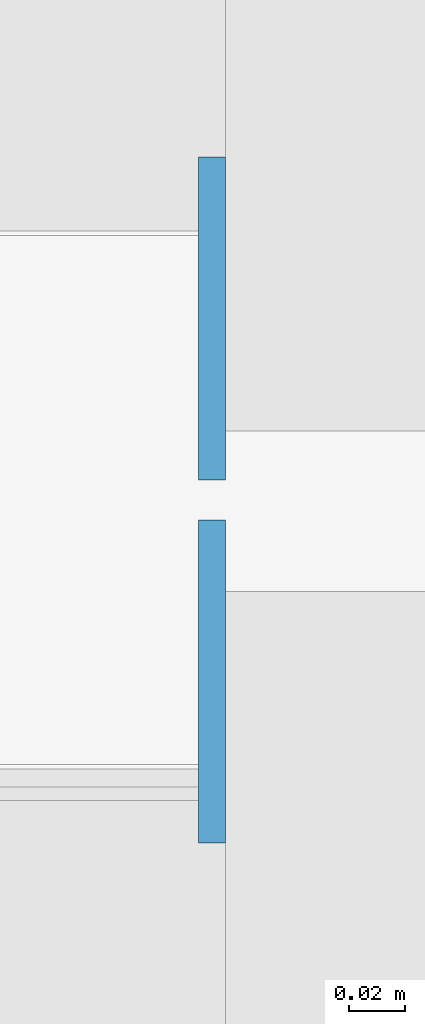
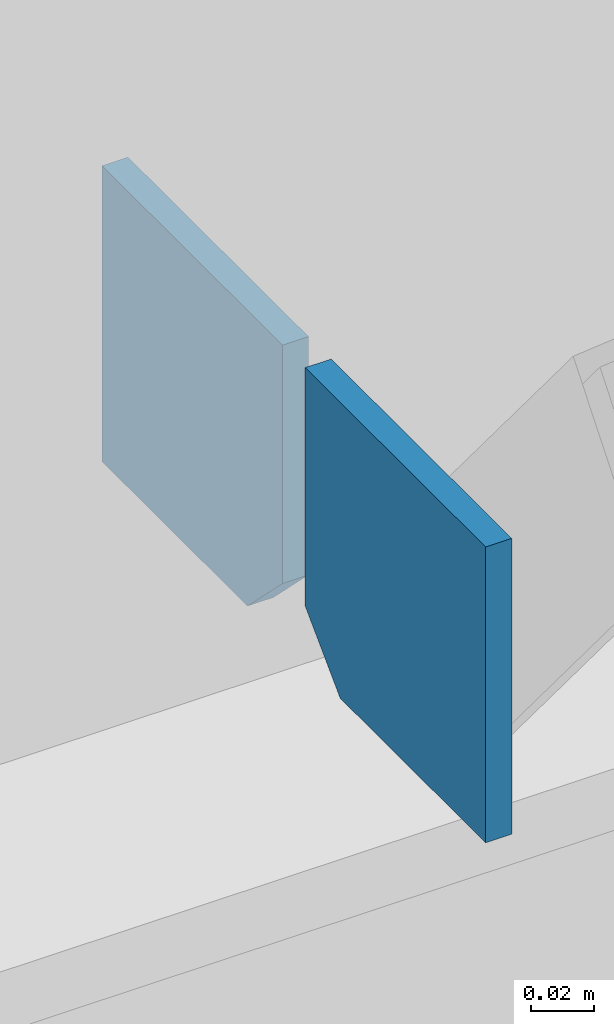
# One storey, part 513 of 1179: 2 columns, 1 element without a shape of its own.
"""IFC2X3 building model written with IfcOpenShell, lengths in millimetres."""

from ifc_helpers import new_model, si_unit, frame, origin_with_axes, place, context, subcontext, project, spatial, faceted_brep, material, type_object, element, aggregate, save


model = new_model("IFC2X3")

# Units and contexts
model_context = context("Model", 3, precision=1e-05, world=origin_with_axes())
body_context = subcontext(model_context, "Body", "Model", "MODEL_VIEW")
ifc_project = project(units=[si_unit("LENGTHUNIT", "METRE", prefix="MILLI"), si_unit("AREAUNIT", "SQUARE_METRE"), si_unit("VOLUMEUNIT", "CUBIC_METRE"), si_unit("MASSUNIT", "GRAM", prefix="KILO"), si_unit("TIMEUNIT", "SECOND"), si_unit("PLANEANGLEUNIT", "RADIAN"), si_unit("SOLIDANGLEUNIT", "STERADIAN"), si_unit("THERMODYNAMICTEMPERATUREUNIT", "DEGREE_CELSIUS"), si_unit("LUMINOUSINTENSITYUNIT", "LUMEN")], contexts=[model_context])

# Site, building, storey
site_placement = place(None, origin_with_axes())
site = spatial("IfcSite", under=ifc_project, at=site_placement, CompositionType="ELEMENT")
building_placement = place(site_placement, origin_with_axes())
building = spatial("IfcBuilding", under=site, at=building_placement, Name="Undefined", CompositionType="ELEMENT")
storey_placement = place(building_placement, origin_with_axes())
storey = spatial("IfcBuildingStorey", under=building, at=storey_placement, Name="Undefined", CompositionType="ELEMENT", Elevation=0.0)

# Assembly, columns
assembly_placement = place(storey_placement, origin_with_axes())
assembly = element("IfcElementAssembly", 1, at=assembly_placement, inside=storey, Name="BEAM", AssemblyPlace="NOTDEFINED", PredefinedType="RIGID_FRAME")
ifc_material = material(Name="STEEL/A36")
column_type = type_object("IfcColumnType", PredefinedType="NOTDEFINED")
column_1_placement = place(assembly_placement, frame((1752.36728739681, 41263.09375, 7488.2375), z_axis=(0.0, -1.0, 0.0), x_axis=(0.0, 0.0, 1.0)))
column_1 = element("IfcColumn", 2, at=column_1_placement, type_object=column_type, material=ifc_material, Name="PLATE", context=body_context, shape_type="Brep", body=[
    faceted_brep([(22.2250000000004, 4.76250000000073, 57.1500000000015), (0.0, 4.76250000000073, 34.9249999999993), (0.0, -4.76250000000073, 34.9249999999993), (22.2250000000004, -4.76250000000073, 57.1500000000015), (114.300000000001, 4.76250000000073, 57.1500000000015), (114.300000000001, 4.76250000000073, -57.1500000000015), (0.0, 4.76250000000073, -57.1500000000015), (114.300000000001, -4.76250000000073, 57.1500000000015), (0.0, -4.76250000000073, -57.1500000000015), (114.300000000001, -4.76250000000073, -57.1500000000015)], [[[0, 1, 2, 3]], [[4, 5, 6, 1, 0]], [[7, 4, 0, 3]], [[8, 9, 7, 3, 2]], [[8, 6, 5, 9]], [[7, 9, 5, 4]], [[6, 8, 2, 1]]]),
])
column_2_placement = place(assembly_placement, frame((1752.36728739681, 41134.50625, 7488.2375), z_axis=(0.0, 1.0, 0.0), x_axis=(0.0, 0.0, 1.0)))
column_2 = element("IfcColumn", 3, at=column_2_placement, type_object=column_type, material=ifc_material, Name="PLATE", context=body_context, shape_type="Brep", body=[
    faceted_brep([(22.2250000000004, 4.76250000000073, 57.1500000000015), (0.0, 4.76250000000073, 34.9249999999993), (0.0, -4.76250000000073, 34.9249999999993), (22.2250000000004, -4.76250000000073, 57.1500000000015), (114.300000000001, 4.76250000000073, 57.1500000000015), (114.300000000001, 4.76250000000073, -57.1500000000015), (0.0, 4.76250000000073, -57.1500000000015), (114.300000000001, -4.76250000000073, 57.1500000000015), (0.0, -4.76250000000073, -57.1500000000015), (114.300000000001, -4.76250000000073, -57.1500000000015)], [[[0, 1, 2, 3]], [[4, 5, 6, 1, 0]], [[7, 4, 0, 3]], [[8, 9, 7, 3, 2]], [[8, 6, 5, 9]], [[7, 9, 5, 4]], [[6, 8, 2, 1]]]),
])
aggregate(assembly, [column_1, column_2])

save(model, "model.ifc")
